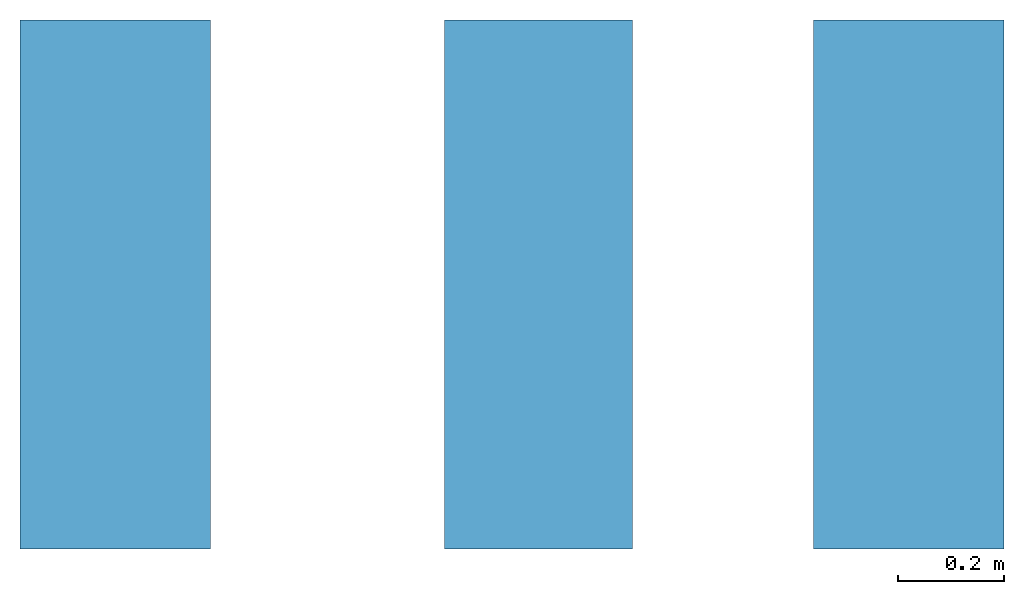
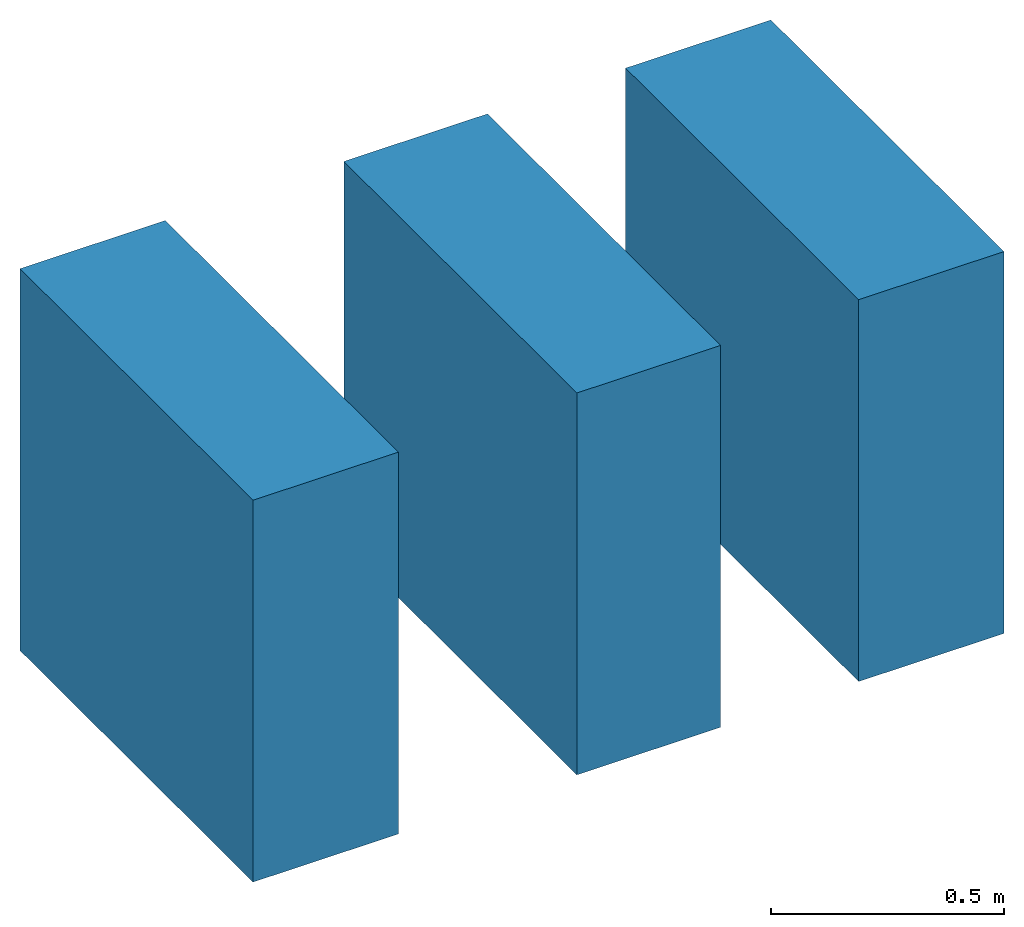
# One storey: 3 walls.
"""IFC2X3 building model written with IfcOpenShell, lengths in millimetres."""

from ifc_helpers import new_model, entity, si_unit, converted_unit, derived_unit, direction, frame, frame_2d, origin, place, context, subcontext, project, spatial, rectangle, extrude, material, layer, layer_set, layer_usage, type_object, element, save


model = new_model("IFC2X3")

# Units and contexts
model_context = context("Model", 3, precision=0.01, world=origin(), true_north=direction((6.12303176911189e-17, 1.0)))
context_of_model = context(None, 3, precision=0.01, world=origin(), true_north=direction((6.12303176911189e-17, 1.0)))
body_context = subcontext(model_context, "Body", "Model", "MODEL_VIEW")
ifc_project = project(units=[si_unit("LENGTHUNIT", "METRE", prefix="MILLI"), si_unit("AREAUNIT", "SQUARE_METRE"), si_unit("VOLUMEUNIT", "CUBIC_METRE"), converted_unit("PLANEANGLEUNIT", "DEGREE", entity("IfcRatioMeasure", 0.0174532925199433), si_unit("PLANEANGLEUNIT", "RADIAN"), dimensions=[0, 0, 0, 0, 0, 0, 0]), si_unit("MASSUNIT", "GRAM", prefix="KILO"), si_unit("TIMEUNIT", "SECOND"), si_unit("FREQUENCYUNIT", "HERTZ"), si_unit("THERMODYNAMICTEMPERATUREUNIT", "DEGREE_CELSIUS"), derived_unit("THERMALTRANSMITTANCEUNIT", [(si_unit("MASSUNIT", "GRAM", prefix="KILO"), 1), (si_unit("THERMODYNAMICTEMPERATUREUNIT", "KELVIN"), -1), (si_unit("TIMEUNIT", "SECOND"), -3)]), derived_unit("VOLUMETRICFLOWRATEUNIT", [(si_unit("LENGTHUNIT", "METRE"), 3), (si_unit("TIMEUNIT", "SECOND"), -1)]), si_unit("ELECTRICCURRENTUNIT", "AMPERE"), si_unit("ELECTRICVOLTAGEUNIT", "VOLT"), si_unit("POWERUNIT", "WATT"), si_unit("FORCEUNIT", "NEWTON", prefix="KILO"), si_unit("ILLUMINANCEUNIT", "LUX"), si_unit("LUMINOUSFLUXUNIT", "LUMEN"), si_unit("LUMINOUSINTENSITYUNIT", "CANDELA"), si_unit("PRESSUREUNIT", "PASCAL")], contexts=[model_context, context_of_model])

# Site, building, storey
site_placement = place(None, origin())
site = spatial("IfcSite", under=ifc_project, at=site_placement, CompositionType="ELEMENT")
building_placement = place(site_placement, origin())
building = spatial("IfcBuilding", under=site, at=building_placement, CompositionType="ELEMENT")
storey_placement = place(building_placement, origin())
storey = spatial("IfcBuildingStorey", under=building, at=storey_placement, CompositionType="ELEMENT", Elevation=0.0)

# Walls
ifc_material_1 = material()
ifc_layer_1 = layer(ifc_material_1, 10.0)
ifc_material_2 = material()
ifc_layer_2 = layer(ifc_material_2, 1.0)
ifc_material_3 = material()
ifc_layer_3 = layer(ifc_material_3, 10.0)
ifc_material_4 = material()
ifc_layer_4 = layer(ifc_material_4, 100.0)
ifc_material_5 = material()
ifc_layer_5 = layer(ifc_material_5, 9.0)
ifc_material_6 = material()
ifc_layer_6 = layer(ifc_material_6, 10.0)
ifc_material_7 = material()
ifc_layer_7 = layer(ifc_material_7, 200.0)
ifc_material_8 = material()
ifc_layer_8 = layer(ifc_material_8, 20.0)
ifc_layer_set_1 = layer_set([ifc_layer_1, ifc_layer_2, ifc_layer_3, ifc_layer_4, ifc_layer_5, ifc_layer_6, ifc_layer_7, ifc_layer_8])
ifc_layer_usage_1 = layer_usage(ifc_layer_set_1, "AXIS2", "POSITIVE", -180.0)
wall_type_1 = type_object("IfcWallType", PredefinedType="STANDARD", material=ifc_layer_set_1)
wall_1_placement = place(storey_placement, frame((2631.90671950462, 3044.93365683083, 0.0), z_axis=(0.0, 0.0, 1.0), x_axis=(0.0, -1.0, 0.0)))
element("IfcWallStandardCase", 1, at=wall_1_placement, inside=storey, type_object=wall_type_1, material=ifc_layer_usage_1, context=body_context, shape_type="SweptSolid", body=[
    extrude(rectangle(XDim=1000.0, YDim=360.0, at=frame_2d((500.0, 0.0), x_axis=(-1.0, 0.0))), origin(), (0.0, 0.0, 1.0), 1000.0),
])
ifc_layer_9 = layer(ifc_material_1, 8.0)
ifc_layer_10 = layer(ifc_material_2, 1.0)
ifc_layer_11 = layer(ifc_material_3, 8.0)
ifc_material_9 = material()
ifc_layer_12 = layer(ifc_material_9, 100.0)
ifc_layer_13 = layer(ifc_material_5, 9.0)
ifc_layer_14 = layer(ifc_material_6, 10.0)
ifc_layer_15 = layer(ifc_material_7, 200.0)
ifc_layer_16 = layer(ifc_material_8, 20.0)
ifc_layer_set_2 = layer_set([ifc_layer_9, ifc_layer_10, ifc_layer_11, ifc_layer_12, ifc_layer_13, ifc_layer_14, ifc_layer_15, ifc_layer_16])
ifc_layer_usage_2 = layer_usage(ifc_layer_set_2, "AXIS2", "POSITIVE", -178.0)
wall_type_2 = type_object("IfcWallType", PredefinedType="STANDARD", material=ifc_layer_set_2)
wall_2_placement = place(storey_placement, frame((3431.90671950462, 3044.93365683083, 0.0), z_axis=(0.0, 0.0, 1.0), x_axis=(0.0, -1.0, 0.0)))
element("IfcWallStandardCase", 2, at=wall_2_placement, inside=storey, type_object=wall_type_2, material=ifc_layer_usage_2, context=body_context, shape_type="SweptSolid", body=[
    extrude(rectangle(XDim=1000.0, YDim=356.0, at=frame_2d((500.0, 0.0), x_axis=(-1.0, 0.0))), origin(), (0.0, 0.0, 1.0), 1000.0),
])
ifc_layer_17 = layer(ifc_material_1, 10.0)
ifc_layer_18 = layer(ifc_material_2, 1.0)
ifc_layer_19 = layer(ifc_material_3, 10.0)
ifc_layer_20 = layer(ifc_material_4, 100.0)
ifc_layer_21 = layer(ifc_material_5, 9.0)
ifc_layer_22 = layer(ifc_material_6, 10.0)
ifc_layer_23 = layer(ifc_material_7, 200.0)
ifc_layer_24 = layer(ifc_material_8, 20.0)
ifc_layer_set_3 = layer_set([ifc_layer_17, ifc_layer_18, ifc_layer_19, ifc_layer_20, ifc_layer_21, ifc_layer_22, ifc_layer_23, ifc_layer_24])
ifc_layer_usage_3 = layer_usage(ifc_layer_set_3, "AXIS2", "POSITIVE", -180.0)
wall_type_3 = type_object("IfcWallType", PredefinedType="STANDARD", material=ifc_layer_set_3)
wall_3_placement = place(storey_placement, frame((4131.90671950462, 3044.93365683083, 0.0), z_axis=(0.0, 0.0, 1.0), x_axis=(0.0, -1.0, 0.0)))
element("IfcWallStandardCase", 3, at=wall_3_placement, inside=storey, type_object=wall_type_3, material=ifc_layer_usage_3, context=body_context, shape_type="SweptSolid", body=[
    extrude(rectangle(XDim=1000.0, YDim=360.0, at=frame_2d((500.0, 0.0), x_axis=(-1.0, 0.0))), origin(), (0.0, 0.0, 1.0), 1000.0),
])

save(model, "model.ifc")
